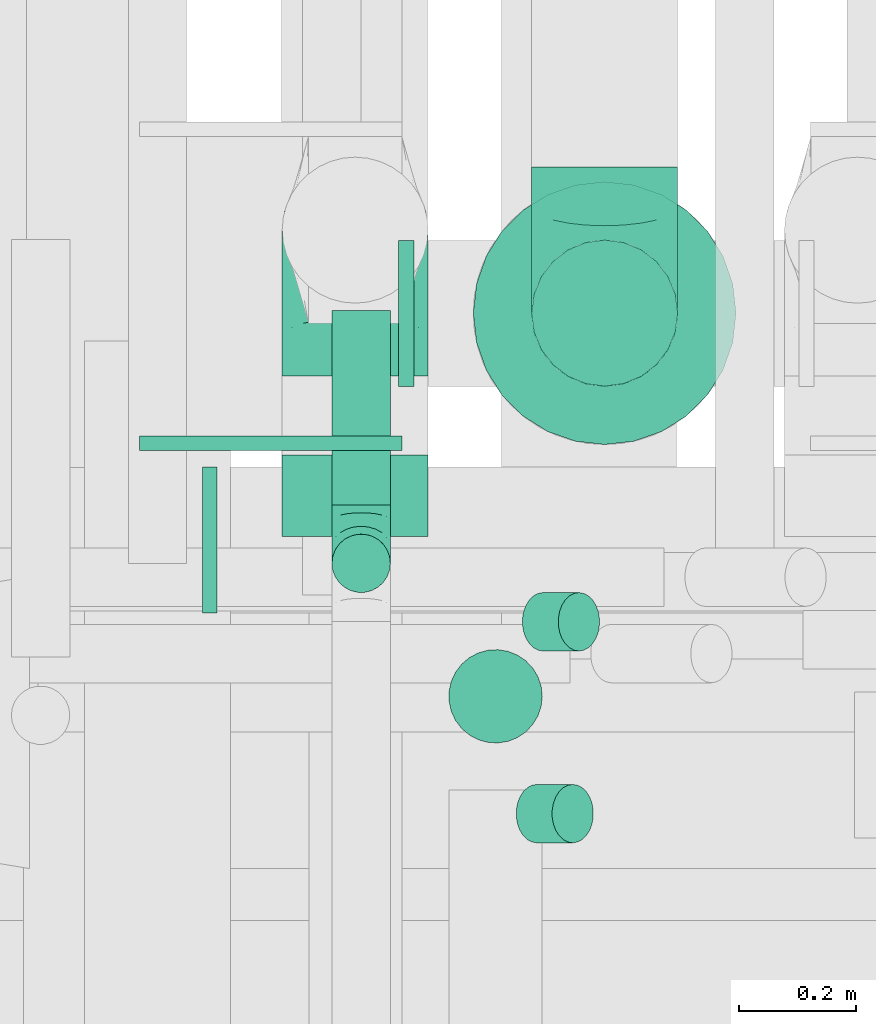
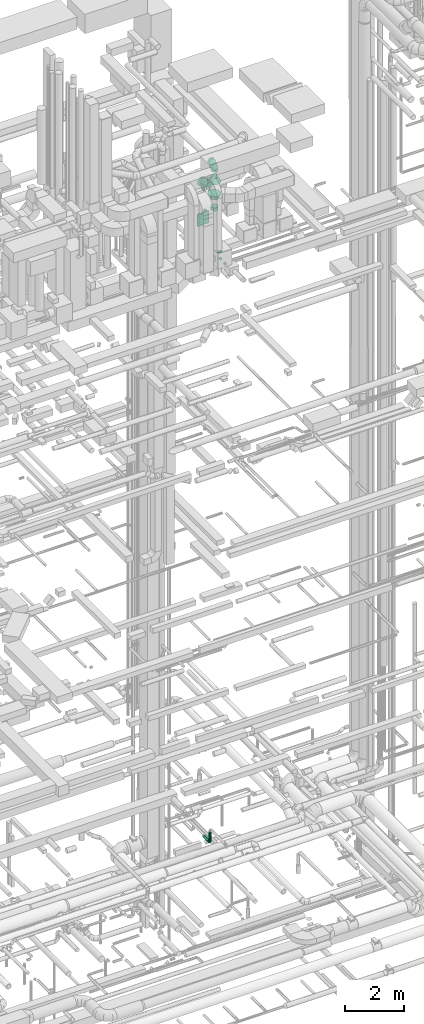
# One storey, part 240 of 337: 10 flow fittings, 5 flow segments.
"""IFC2X3 building model written with IfcOpenShell, lengths in millimetres."""

from ifc_helpers import new_model, entity, si_unit, converted_unit, derived_unit, direction, frame, origin, origin_2d_with_axis, place, context, subcontext, project, spatial, rectangle, circle, extrude, faceted_brep, source, transform, mapped, material, type_object, type_shapes, element, save


model = new_model("IFC2X3")

# Units and contexts
model_context = context("Model", 3, precision=0.01, world=origin(), true_north=direction((6.12303176911189e-17, 1.0)))
body_context = subcontext(model_context, "Body", "Model", "MODEL_VIEW")
ifc_project = project(units=[si_unit("LENGTHUNIT", "METRE", prefix="MILLI"), si_unit("AREAUNIT", "SQUARE_METRE"), si_unit("VOLUMEUNIT", "CUBIC_METRE"), converted_unit("PLANEANGLEUNIT", "DEGREE", entity("IfcRatioMeasure", 0.0174532925199433), si_unit("PLANEANGLEUNIT", "RADIAN"), dimensions=[0, 0, 0, 0, 0, 0, 0]), si_unit("MASSUNIT", "GRAM", prefix="KILO"), derived_unit("MASSDENSITYUNIT", [(si_unit("MASSUNIT", "GRAM", prefix="KILO"), 1), (si_unit("LENGTHUNIT", "METRE"), -3)]), derived_unit("MOMENTOFINERTIAUNIT", [(si_unit("LENGTHUNIT", "METRE"), 4)]), si_unit("TIMEUNIT", "SECOND"), si_unit("FREQUENCYUNIT", "HERTZ"), si_unit("THERMODYNAMICTEMPERATUREUNIT", "DEGREE_CELSIUS"), derived_unit("THERMALTRANSMITTANCEUNIT", [(si_unit("MASSUNIT", "GRAM", prefix="KILO"), 1), (si_unit("THERMODYNAMICTEMPERATUREUNIT", "KELVIN"), -1), (si_unit("TIMEUNIT", "SECOND"), -3)]), derived_unit("VOLUMETRICFLOWRATEUNIT", [(si_unit("LENGTHUNIT", "METRE"), 3), (si_unit("TIMEUNIT", "SECOND"), -1)]), derived_unit("MASSFLOWRATEUNIT", [(si_unit("MASSUNIT", "GRAM", prefix="KILO"), 1), (si_unit("TIMEUNIT", "SECOND"), -1)]), derived_unit("ROTATIONALFREQUENCYUNIT", [(si_unit("TIMEUNIT", "SECOND"), -1)]), si_unit("ELECTRICCURRENTUNIT", "AMPERE"), si_unit("ELECTRICVOLTAGEUNIT", "VOLT"), si_unit("POWERUNIT", "WATT"), si_unit("FORCEUNIT", "NEWTON", prefix="KILO"), si_unit("ILLUMINANCEUNIT", "LUX"), si_unit("LUMINOUSFLUXUNIT", "LUMEN"), si_unit("LUMINOUSINTENSITYUNIT", "CANDELA"), derived_unit("USERDEFINED", [(si_unit("MASSUNIT", "GRAM", prefix="KILO"), -1), (si_unit("LENGTHUNIT", "METRE"), -2), (si_unit("TIMEUNIT", "SECOND"), 3), (si_unit("LUMINOUSFLUXUNIT", "LUMEN"), 1)]), derived_unit("LINEARVELOCITYUNIT", [(si_unit("LENGTHUNIT", "METRE"), 1), (si_unit("TIMEUNIT", "SECOND"), -1)]), si_unit("PRESSUREUNIT", "PASCAL"), derived_unit("USERDEFINED", [(si_unit("LENGTHUNIT", "METRE"), -2), (si_unit("MASSUNIT", "GRAM", prefix="KILO"), 1), (si_unit("TIMEUNIT", "SECOND"), -2)]), derived_unit("LINEARFORCEUNIT", [(si_unit("MASSUNIT", "GRAM", prefix="KILO"), 1), (si_unit("LENGTHUNIT", "METRE"), 1), (si_unit("TIMEUNIT", "SECOND"), -2), (si_unit("LENGTHUNIT", "METRE"), -1)]), derived_unit("PLANARFORCEUNIT", [(si_unit("MASSUNIT", "GRAM", prefix="KILO"), 1), (si_unit("LENGTHUNIT", "METRE"), 1), (si_unit("TIMEUNIT", "SECOND"), -2), (si_unit("LENGTHUNIT", "METRE"), -2)])], contexts=[model_context])

# Site, building, storey
site_placement = place(None, origin())
site = spatial("IfcSite", under=ifc_project, at=site_placement, CompositionType="ELEMENT")
building_placement = place(site_placement, origin())
building = spatial("IfcBuilding", under=site, at=building_placement, CompositionType="ELEMENT")
storey_placement = place(building_placement, origin())
storey = spatial("IfcBuildingStorey", under=building, at=storey_placement, CompositionType="ELEMENT", Elevation=0.0)

# Flow segments
duct_segment_type = type_object("IfcDuctSegmentType", PredefinedType="NOTDEFINED")
flow_segment_1_placement = place(storey_placement, frame((60646.81, 10410.09, 3098.4)))
element("IfcFlowSegment", 1, at=flow_segment_1_placement, inside=storey, type_object=duct_segment_type, context=body_context, shape_type="SweptSolid", body=[
    extrude(circle(Radius=50.0, at=origin_2d_with_axis()), frame((51.6, 0.0, 51.6), z_axis=(0.0, 1.0, 0.0), x_axis=(1.0, 0.0, 0.0)), (0.0, 0.0, 1.0), 332.897563299893),
])
flow_segment_2_placement = place(storey_placement, frame((60846.85, 10000.81, 27460.0)))
element("IfcFlowSegment", 2, at=flow_segment_2_placement, inside=storey, type_object=duct_segment_type, context=body_context, shape_type="SweptSolid", body=[
    extrude(circle(Radius=80.0, at=origin_2d_with_axis()), frame((81.6, 81.6, 0.0)), (0.0, 0.0, 1.0), 19.9999999999608),
])
flow_segment_3_placement = place(storey_placement, frame((60962.21, 9829.93, 26992.34)))
element("IfcFlowSegment", 3, at=flow_segment_3_placement, inside=storey, type_object=duct_segment_type, context=body_context, shape_type="SweptSolid", body=[
    extrude(circle(Radius=50.0, at=origin_2d_with_axis()), frame((36.95, 51.6, 36.95), z_axis=(0.707106781186468, 0.0, 0.707106781186627), x_axis=(0.0, 1.0, 0.0)), (0.0, 0.0, 1.0), 86.8629150101547),
])
flow_segment_4_placement = place(storey_placement, frame((60972.83, 10158.38, 26992.34)))
element("IfcFlowSegment", 4, at=flow_segment_4_placement, inside=storey, type_object=duct_segment_type, context=body_context, shape_type="SweptSolid", body=[
    extrude(circle(Radius=50.0, at=origin_2d_with_axis()), frame((36.95, 51.6, 36.95), z_axis=(0.707106781186555, 0.0, 0.70710678118654), x_axis=(0.0, -1.0, 0.0)), (0.0, 0.0, 1.0), 86.8629150101424),
])
flow_segment_5_placement = place(storey_placement, frame((60646.81, 10258.49, 3250.0)))
element("IfcFlowSegment", 5, at=flow_segment_5_placement, inside=storey, type_object=duct_segment_type, context=body_context, shape_type="SweptSolid", body=[
    extrude(circle(Radius=50.0, at=origin_2d_with_axis()), frame((51.6, 51.6, 0.0), z_axis=(0.0, 0.0, 1.0), x_axis=(-1.0, 0.0, 0.0)), (0.0, 0.0, 1.0), 350.000000000019),
])

# Flow fittings
ifc_material = material()
duct_fitting_type_1 = type_object("IfcDuctFittingType", PredefinedType="NOTDEFINED", material=ifc_material)
shared_shape_1 = source(origin(), body_context, "Body", "SweptSolid", [
    extrude(circle(Radius=124.999999999999, at=origin_2d_with_axis()), frame((0.0, 0.0, 0.0), z_axis=(1.0, 0.0, 0.0), x_axis=(0.0, 1.0, 0.0)), (0.0, 0.0, 1.0), 25.0000000000018),
])
type_shapes(duct_fitting_type_1, [shared_shape_1])
flow_fitting_1_placement = place(storey_placement, frame((60451.97, 10350.19, 30100.0), z_axis=(0.0, 0.0, 1.0), x_axis=(-1.0, 0.0, 0.0)))
element("IfcFlowFitting", 6, at=flow_fitting_1_placement, inside=storey, type_object=duct_fitting_type_1, material=ifc_material, context=body_context, shape_type="MappedRepresentation", body=[
    mapped(shared_shape_1, transform((0.0, 0.0, 0.0), scale=1.0)),
])
duct_fitting_type_2 = type_object("IfcDuctFittingType", PredefinedType="NOTDEFINED", material=ifc_material)
shared_shape_2 = source(origin(), body_context, "Body", "SweptSolid", [
    extrude(rectangle(XDim=24.9999999999999, YDim=450.0, at=origin_2d_with_axis()), frame((12.5, 0.0, -250.0)), (0.0, 0.0, 1.0), 500.0),
])
type_shapes(duct_fitting_type_2, [shared_shape_2])
flow_fitting_2_placement = place(storey_placement, frame((60543.66, 10528.49, 28700.0), z_axis=(0.0, 0.0, 1.0), x_axis=(0.0, -1.0, 0.0)))
element("IfcFlowFitting", 7, at=flow_fitting_2_placement, inside=storey, type_object=duct_fitting_type_2, material=ifc_material, context=body_context, shape_type="MappedRepresentation", body=[
    mapped(shared_shape_2, transform((0.0, 0.0, 0.0), scale=1.0)),
])
duct_fitting_type_3 = type_object("IfcDuctFittingType", PredefinedType="NOTDEFINED", material=ifc_material)
shared_shape_3 = source(origin(), body_context, "Body", "Brep", [
    faceted_brep([(-100.0, 0.0, -50.0), (-100.0, -12.94, -48.3), (-100.0, -25.0, -43.3), (-100.0, -35.36, -35.36), (-100.0, -43.3, -25.0), (-100.0, -48.3, -12.94), (-100.0, -50.0, 0.0), (-100.0, -48.3, 12.94), (-100.0, -43.3, 25.0), (-100.0, -35.36, 35.36), (-100.0, -25.0, 43.3), (-100.0, -12.94, 48.3), (-100.0, 0.0, 50.0), (-100.0, 12.94, 48.3), (-100.0, 25.0, 43.3), (-100.0, 35.36, 35.36), (-100.0, 43.3, 25.0), (-100.0, 48.3, 12.94), (-100.0, 50.0, 0.0), (-100.0, 48.3, -12.94), (-100.0, 43.3, -25.0), (-100.0, 35.36, -35.36), (-100.0, 25.0, -43.3), (-100.0, 12.94, -48.3), (-76.67, 12.94, 48.3), (-79.9, 25.0, 43.3), (-73.21, 0.0, 50.0), (-82.68, 35.36, 35.36), (-86.15, 48.3, 12.94), (-86.6, 50.0, 0.0), (-84.81, 43.3, 25.0), (-84.81, 43.3, -25.0), (-82.68, 35.36, -35.36), (-86.15, 48.3, -12.94), (-76.67, 12.94, -48.3), (-73.21, 0.0, -50.0), (-79.9, 25.0, -43.3), (-69.74, -12.94, -48.3), (-66.51, -25.0, -43.3), (-63.73, -35.36, -35.36), (-61.6, -43.3, -25.0), (-60.26, -48.3, -12.94), (-59.81, -50.0, 0.0), (-60.26, -48.3, 12.94), (-61.6, -43.3, 25.0), (-63.73, -35.36, 35.36), (-66.51, -25.0, 43.3), (-69.74, -12.94, 48.3), (-36.27, 36.27, 48.3), (-45.1, 45.1, 43.3), (-26.79, 26.79, 50.0), (-52.68, 52.68, 35.36), (-58.49, 58.49, 25.0), (-62.15, 62.15, 12.94), (-63.4, 63.4, 0.0), (-62.15, 62.15, -12.94), (-58.49, 58.49, -25.0), (-52.68, 52.68, -35.36), (-36.27, 36.27, -48.3), (-26.79, 26.79, -50.0), (-45.1, 45.1, -43.3), (-17.32, 17.32, -48.3), (-8.49, 8.49, -43.3), (-0.91, 0.91, -35.36), (4.9, -4.9, -25.0), (8.56, -8.56, -12.94), (9.81, -9.81, 0.0), (8.56, -8.56, 12.94), (4.9, -4.9, 25.0), (-0.91, 0.91, 35.36), (-8.49, 8.49, 43.3), (-17.32, 17.32, 48.3), (-12.94, 76.67, 48.3), (-25.0, 79.9, 43.3), (0.0, 73.21, 50.0), (-35.36, 82.68, 35.36), (-43.3, 84.81, 25.0), (-48.3, 86.15, 12.94), (-50.0, 86.6, 0.0), (-48.3, 86.15, -12.94), (-43.3, 84.81, -25.0), (-35.36, 82.68, -35.36), (-12.94, 76.67, -48.3), (0.0, 73.21, -50.0), (-25.0, 79.9, -43.3), (12.94, 69.74, -48.3), (25.0, 66.51, -43.3), (35.36, 63.73, -35.36), (43.3, 61.6, -25.0), (48.3, 60.26, -12.94), (50.0, 59.81, 0.0), (48.3, 60.26, 12.94), (43.3, 61.6, 25.0), (35.36, 63.73, 35.36), (25.0, 66.51, 43.3), (12.94, 69.74, 48.3), (-12.94, 100.0, -48.3), (-25.0, 100.0, -43.3), (-35.36, 100.0, -35.36), (-43.3, 100.0, -25.0), (-48.3, 100.0, -12.94), (-50.0, 100.0, 0.0), (-48.3, 100.0, 12.94), (-43.3, 100.0, 25.0), (-35.36, 100.0, 35.36), (-25.0, 100.0, 43.3), (-12.94, 100.0, 48.3), (0.0, 100.0, 50.0), (12.94, 100.0, 48.3), (25.0, 100.0, 43.3), (35.36, 100.0, 35.36), (43.3, 100.0, 25.0), (48.3, 100.0, 12.94), (50.0, 100.0, 0.0), (48.3, 100.0, -12.94), (43.3, 100.0, -25.0), (35.36, 100.0, -35.36), (25.0, 100.0, -43.3), (12.94, 100.0, -48.3), (0.0, 100.0, -50.0)], [[[0, 1, 2, 3, 4, 5, 6, 7, 8, 9, 10, 11, 12, 13, 14, 15, 16, 17, 18, 19, 20, 21, 22, 23]], [[24, 25, 14, 13]], [[26, 24, 13, 12]], [[14, 25, 27, 15]], [[28, 29, 18, 17]], [[30, 28, 17, 16]], [[15, 27, 30, 16]], [[20, 31, 32, 21]], [[33, 31, 20, 19]], [[18, 29, 33, 19]], [[34, 35, 0, 23]], [[36, 34, 23, 22]], [[32, 36, 22, 21]], [[2, 1, 37, 38]], [[3, 2, 38, 39]], [[0, 35, 37, 1]], [[5, 4, 40, 41]], [[6, 5, 41, 42]], [[3, 39, 40, 4]], [[6, 42, 43, 7]], [[7, 43, 44, 8]], [[8, 44, 45, 9]], [[10, 46, 47, 11]], [[11, 47, 26, 12]], [[10, 9, 45, 46]], [[48, 49, 25, 24]], [[50, 48, 24, 26]], [[27, 25, 49, 51]], [[52, 53, 28, 30]], [[51, 52, 30, 27]], [[29, 28, 53, 54]], [[55, 56, 31, 33]], [[54, 55, 33, 29]], [[57, 32, 31, 56]], [[58, 59, 35, 34]], [[60, 58, 34, 36]], [[57, 60, 36, 32]], [[37, 35, 59, 61]], [[38, 37, 61, 62]], [[39, 38, 62, 63]], [[41, 40, 64, 65]], [[42, 41, 65, 66]], [[63, 64, 40, 39]], [[43, 42, 66, 67]], [[44, 43, 67, 68]], [[68, 69, 45, 44]], [[46, 45, 69, 70]], [[47, 46, 70, 71]], [[26, 47, 71, 50]], [[72, 73, 49, 48]], [[74, 72, 48, 50]], [[51, 49, 73, 75]], [[76, 77, 53, 52]], [[75, 76, 52, 51]], [[54, 53, 77, 78]], [[79, 80, 56, 55]], [[78, 79, 55, 54]], [[81, 57, 56, 80]], [[82, 83, 59, 58]], [[84, 82, 58, 60]], [[81, 84, 60, 57]], [[61, 59, 83, 85]], [[62, 61, 85, 86]], [[63, 62, 86, 87]], [[65, 64, 88, 89]], [[66, 65, 89, 90]], [[87, 88, 64, 63]], [[67, 66, 90, 91]], [[68, 67, 91, 92]], [[92, 93, 69, 68]], [[70, 69, 93, 94]], [[71, 70, 94, 95]], [[50, 71, 95, 74]], [[96, 97, 98, 99, 100, 101, 102, 103, 104, 105, 106, 107, 108, 109, 110, 111, 112, 113, 114, 115, 116, 117, 118, 119]], [[72, 74, 107, 106]], [[73, 72, 106, 105]], [[75, 73, 105, 104]], [[77, 76, 103, 102]], [[78, 77, 102, 101]], [[75, 104, 103, 76]], [[78, 101, 100, 79]], [[79, 100, 99, 80]], [[80, 99, 98, 81]], [[96, 119, 83, 82]], [[97, 96, 82, 84]], [[84, 81, 98, 97]], [[83, 119, 118, 85]], [[85, 118, 117, 86]], [[86, 117, 116, 87]], [[88, 115, 114, 89]], [[89, 114, 113, 90]], [[87, 116, 115, 88]], [[91, 90, 113, 112]], [[92, 91, 112, 111]], [[93, 92, 111, 110]], [[95, 94, 109, 108]], [[74, 95, 108, 107]], [[110, 109, 94, 93]]]),
])
type_shapes(duct_fitting_type_3, [shared_shape_3])
flow_fitting_3_placement = place(storey_placement, frame((60698.4, 10310.09, 3150.0), z_axis=(-1.0, 0.0, 0.0), x_axis=(0.0, -1.0, 0.0)))
element("IfcFlowFitting", 8, at=flow_fitting_3_placement, inside=storey, type_object=duct_fitting_type_3, material=ifc_material, context=body_context, shape_type="MappedRepresentation", body=[
    mapped(shared_shape_3, transform((0.0, 0.0, 0.0), scale=1.0)),
])
duct_fitting_type_4 = type_object("IfcDuctFittingType", PredefinedType="NOTDEFINED", material=ifc_material)
shared_shape_4 = source(origin(), body_context, "Body", "Brep", [
    faceted_brep([(-250.0, 0.0, -125.0), (-250.0, -32.35, -120.74), (-250.0, -62.5, -108.25), (-250.0, -88.39, -88.39), (-250.0, -108.25, -62.5), (-250.0, -120.74, -32.35), (-250.0, -125.0, 0.0), (-250.0, -120.74, 32.35), (-250.0, -108.25, 62.5), (-250.0, -88.39, 88.39), (-250.0, -62.5, 108.25), (-250.0, -32.35, 120.74), (-250.0, 0.0, 125.0), (-250.0, 32.35, 120.74), (-250.0, 62.5, 108.25), (-250.0, 88.39, 88.39), (-250.0, 108.25, 62.5), (-250.0, 120.74, 32.35), (-250.0, 125.0, 0.0), (-250.0, 120.74, -32.35), (-250.0, 108.25, -62.5), (-250.0, 88.39, -88.39), (-250.0, 62.5, -108.25), (-250.0, 32.35, -120.74), (-191.68, 32.35, 120.74), (-199.76, 62.5, 108.25), (-183.01, 0.0, 125.0), (-206.7, 88.39, 88.39), (-215.37, 120.74, 32.35), (-216.51, 125.0, 0.0), (-212.02, 108.25, 62.5), (-212.02, 108.25, -62.5), (-206.7, 88.39, -88.39), (-215.37, 120.74, -32.35), (-191.68, 32.35, -120.74), (-183.01, 0.0, -125.0), (-199.76, 62.5, -108.25), (-174.34, -32.35, -120.74), (-166.27, -62.5, -108.25), (-159.33, -88.39, -88.39), (-154.01, -108.25, -62.5), (-150.66, -120.74, -32.35), (-149.52, -125.0, 0.0), (-150.66, -120.74, 32.35), (-154.01, -108.25, 62.5), (-159.33, -88.39, 88.39), (-166.27, -62.5, 108.25), (-174.34, -32.35, 120.74), (-90.67, 90.67, 120.74), (-112.74, 112.74, 108.25), (-66.99, 66.99, 125.0), (-131.69, 131.69, 88.39), (-146.23, 146.23, 62.5), (-155.38, 155.38, 32.35), (-158.49, 158.49, 0.0), (-155.38, 155.38, -32.35), (-146.23, 146.23, -62.5), (-131.69, 131.69, -88.39), (-90.67, 90.67, -120.74), (-66.99, 66.99, -125.0), (-112.74, 112.74, -108.25), (-43.3, 43.3, -120.74), (-21.23, 21.23, -108.25), (-2.28, 2.28, -88.39), (12.26, -12.26, -62.5), (21.4, -21.4, -32.35), (24.52, -24.52, 0.0), (21.4, -21.4, 32.35), (12.26, -12.26, 62.5), (-2.28, 2.28, 88.39), (-21.23, 21.23, 108.25), (-43.3, 43.3, 120.74), (-32.35, 191.68, 120.74), (-62.5, 199.76, 108.25), (0.0, 183.01, 125.0), (-88.39, 206.7, 88.39), (-108.25, 212.02, 62.5), (-120.74, 215.37, 32.35), (-125.0, 216.51, 0.0), (-120.74, 215.37, -32.35), (-108.25, 212.02, -62.5), (-88.39, 206.7, -88.39), (-32.35, 191.68, -120.74), (0.0, 183.01, -125.0), (-62.5, 199.76, -108.25), (32.35, 174.34, -120.74), (62.5, 166.27, -108.25), (88.39, 159.33, -88.39), (108.25, 154.01, -62.5), (120.74, 150.66, -32.35), (125.0, 149.52, 0.0), (120.74, 150.66, 32.35), (108.25, 154.01, 62.5), (88.39, 159.33, 88.39), (62.5, 166.27, 108.25), (32.35, 174.34, 120.74), (-32.35, 250.0, -120.74), (-62.5, 250.0, -108.25), (-88.39, 250.0, -88.39), (-108.25, 250.0, -62.5), (-120.74, 250.0, -32.35), (-125.0, 250.0, 0.0), (-120.74, 250.0, 32.35), (-108.25, 250.0, 62.5), (-88.39, 250.0, 88.39), (-62.5, 250.0, 108.25), (-32.35, 250.0, 120.74), (0.0, 250.0, 125.0), (32.35, 250.0, 120.74), (62.5, 250.0, 108.25), (88.39, 250.0, 88.39), (108.25, 250.0, 62.5), (120.74, 250.0, 32.35), (125.0, 250.0, 0.0), (120.74, 250.0, -32.35), (108.25, 250.0, -62.5), (88.39, 250.0, -88.39), (62.5, 250.0, -108.25), (32.35, 250.0, -120.74), (0.0, 250.0, -125.0)], [[[0, 1, 2, 3, 4, 5, 6, 7, 8, 9, 10, 11, 12, 13, 14, 15, 16, 17, 18, 19, 20, 21, 22, 23]], [[24, 25, 14, 13]], [[26, 24, 13, 12]], [[14, 25, 27, 15]], [[28, 29, 18, 17]], [[30, 28, 17, 16]], [[15, 27, 30, 16]], [[20, 31, 32, 21]], [[33, 31, 20, 19]], [[18, 29, 33, 19]], [[34, 35, 0, 23]], [[36, 34, 23, 22]], [[21, 32, 36, 22]], [[1, 0, 35, 37]], [[2, 1, 37, 38]], [[38, 39, 3, 2]], [[5, 4, 40, 41]], [[6, 5, 41, 42]], [[39, 40, 4, 3]], [[6, 42, 43, 7]], [[7, 43, 44, 8]], [[8, 44, 45, 9]], [[9, 45, 46, 10]], [[10, 46, 47, 11]], [[26, 12, 11, 47]], [[48, 49, 25, 24]], [[50, 48, 24, 26]], [[27, 25, 49, 51]], [[52, 53, 28, 30]], [[51, 52, 30, 27]], [[29, 28, 53, 54]], [[55, 56, 31, 33]], [[54, 55, 33, 29]], [[32, 31, 56, 57]], [[58, 59, 35, 34]], [[60, 58, 34, 36]], [[57, 60, 36, 32]], [[37, 35, 59, 61]], [[38, 37, 61, 62]], [[39, 38, 62, 63]], [[41, 40, 64, 65]], [[42, 41, 65, 66]], [[63, 64, 40, 39]], [[43, 42, 66, 67]], [[44, 43, 67, 68]], [[68, 69, 45, 44]], [[46, 45, 69, 70]], [[47, 46, 70, 71]], [[26, 47, 71, 50]], [[72, 73, 49, 48]], [[74, 72, 48, 50]], [[51, 49, 73, 75]], [[76, 77, 53, 52]], [[75, 76, 52, 51]], [[54, 53, 77, 78]], [[79, 80, 56, 55]], [[78, 79, 55, 54]], [[57, 56, 80, 81]], [[82, 83, 59, 58]], [[84, 82, 58, 60]], [[81, 84, 60, 57]], [[61, 59, 83, 85]], [[62, 61, 85, 86]], [[63, 62, 86, 87]], [[65, 64, 88, 89]], [[66, 65, 89, 90]], [[87, 88, 64, 63]], [[67, 66, 90, 91]], [[68, 67, 91, 92]], [[92, 93, 69, 68]], [[70, 69, 93, 94]], [[71, 70, 94, 95]], [[50, 71, 95, 74]], [[96, 97, 98, 99, 100, 101, 102, 103, 104, 105, 106, 107, 108, 109, 110, 111, 112, 113, 114, 115, 116, 117, 118, 119]], [[72, 74, 107, 106]], [[73, 72, 106, 105]], [[75, 73, 105, 104]], [[77, 76, 103, 102]], [[78, 77, 102, 101]], [[75, 104, 103, 76]], [[78, 101, 100, 79]], [[79, 100, 99, 80]], [[80, 99, 98, 81]], [[84, 97, 96, 82]], [[82, 96, 119, 83]], [[84, 81, 98, 97]], [[83, 119, 118, 85]], [[85, 118, 117, 86]], [[116, 87, 86, 117]], [[88, 115, 114, 89]], [[89, 114, 113, 90]], [[115, 88, 87, 116]], [[91, 90, 113, 112]], [[92, 91, 112, 111]], [[111, 110, 93, 92]], [[95, 94, 109, 108]], [[74, 95, 108, 107]], [[110, 109, 94, 93]]]),
])
type_shapes(duct_fitting_type_4, [shared_shape_4])
for number, where, z_axis, x_axis in (
    (9, (60688.16, 10880.49, 30100.0), (1.0, 0.0, 0.0), (0.0, 0.0, 1.0)),
    (10, (61115.3, 10738.49, 30600.0), (-1.0, 0.0, 0.0), (0.0, 0.0, 1.0)),
):
    element("IfcFlowFitting", number, at=place(storey_placement, frame(where, z_axis=z_axis, x_axis=x_axis)), inside=storey, type_object=duct_fitting_type_4, material=ifc_material, context=body_context, shape_type="MappedRepresentation", body=[
        mapped(shared_shape_4, transform((0.0, 0.0, 0.0), scale=1.0)),
    ])
duct_fitting_type_5 = type_object("IfcDuctFittingType", PredefinedType="NOTDEFINED", material=ifc_material)
shared_shape_5 = source(origin(), body_context, "Body", "Brep", [
    faceted_brep([(20.0, 0.0, -125.0), (20.0, 32.35, -120.74), (20.0, 62.5, -108.25), (20.0, 88.39, -88.39), (20.0, 108.25, -62.5), (20.0, 120.74, -32.35), (20.0, 125.0, 0.0), (20.0, 120.74, 32.35), (20.0, 108.25, 62.5), (20.0, 88.39, 88.39), (20.0, 62.5, 108.25), (20.0, 32.35, 120.74), (20.0, 0.0, 125.0), (20.0, -32.35, 120.74), (20.0, -62.5, 108.25), (20.0, -88.39, 88.39), (20.0, -108.25, 62.5), (20.0, -120.74, 32.35), (20.0, -125.0, 0.0), (20.0, -120.74, -32.35), (20.0, -108.25, -62.5), (20.0, -88.39, -88.39), (20.0, -62.5, -108.25), (20.0, -32.35, -120.74), (0.0, 0.0, 125.0), (-6.1, 0.0, 125.0), (-6.1, -32.35, 120.74), (0.0, -32.35, 120.74), (-6.1, -62.5, 108.25), (0.0, -62.5, 108.25), (0.0, -88.39, 88.39), (-6.1, -88.39, 88.39), (0.0, -108.25, 62.5), (-6.1, -108.25, 62.5), (-6.1, -120.74, 32.35), (0.0, -120.74, 32.35), (-6.1, -125.0, 0.0), (0.0, -125.0, 0.0), (-6.1, -120.74, -32.35), (0.0, -120.74, -32.35), (-6.1, -108.25, -62.5), (0.0, -108.25, -62.5), (0.0, -88.39, -88.39), (-6.1, -88.39, -88.39), (0.0, -62.5, -108.25), (-6.1, -62.5, -108.25), (-6.1, -32.35, -120.74), (0.0, -32.35, -120.74), (-6.1, 0.0, -125.0), (0.0, 0.0, -125.0), (-6.1, 32.35, -120.74), (0.0, 32.35, -120.74), (-6.1, 62.5, -108.25), (0.0, 62.5, -108.25), (0.0, 88.39, -88.39), (-6.1, 88.39, -88.39), (0.0, 108.25, -62.5), (-6.1, 108.25, -62.5), (-6.1, 120.74, -32.35), (0.0, 120.74, -32.35), (-6.1, 125.0, 0.0), (0.0, 125.0, 0.0), (-6.1, 120.74, 32.35), (0.0, 120.74, 32.35), (-6.1, 108.25, 62.5), (0.0, 108.25, 62.5), (0.0, 88.39, 88.39), (-6.1, 88.39, 88.39), (0.0, 62.5, 108.25), (-6.1, 62.5, 108.25), (-6.1, 32.35, 120.74), (0.0, 32.35, 120.74)], [[[0, 1, 2, 3, 4, 5, 6, 7, 8, 9, 10, 11, 12, 13, 14, 15, 16, 17, 18, 19, 20, 21, 22, 23]], [[13, 12, 24, 25, 26, 27]], [[14, 13, 27, 26, 28, 29]], [[30, 15, 14, 29, 28, 31]], [[17, 16, 32, 33, 34, 35]], [[18, 17, 35, 34, 36, 37]], [[32, 16, 15, 30, 31, 33]], [[19, 18, 37, 36, 38, 39]], [[20, 19, 39, 38, 40, 41]], [[42, 21, 20, 41, 40, 43]], [[23, 22, 44, 45, 46, 47]], [[0, 23, 47, 46, 48, 49]], [[44, 22, 21, 42, 43, 45]], [[1, 0, 49, 48, 50, 51]], [[2, 1, 51, 50, 52, 53]], [[54, 3, 2, 53, 52, 55]], [[5, 4, 56, 57, 58, 59]], [[6, 5, 59, 58, 60, 61]], [[56, 4, 3, 54, 55, 57]], [[7, 6, 61, 60, 62, 63]], [[8, 7, 63, 62, 64, 65]], [[66, 9, 8, 65, 64, 67]], [[11, 10, 68, 69, 70, 71]], [[12, 11, 71, 70, 25, 24]], [[68, 10, 9, 66, 67, 69]], [[46, 45, 43, 40, 38, 36, 34, 33, 31, 28, 26, 25, 70, 69, 67, 64, 62, 60, 58, 57, 55, 52, 50, 48]]]),
])
type_shapes(duct_fitting_type_5, [shared_shape_5])
flow_fitting_4_placement = place(storey_placement, frame((60768.66, 10737.49, 28740.0), z_axis=(0.0, 0.0, -1.0), x_axis=(1.0, 0.0, 0.0)))
element("IfcFlowFitting", 11, at=flow_fitting_4_placement, inside=storey, type_object=duct_fitting_type_5, material=ifc_material, context=body_context, shape_type="MappedRepresentation", body=[
    mapped(shared_shape_5, transform((0.0, 0.0, 0.0), scale=1.0)),
])
duct_fitting_type_6 = type_object("IfcDuctFittingType", PredefinedType="NOTDEFINED", material=ifc_material)
shared_shape_6 = source(origin(), body_context, "Body", "Brep", [
    faceted_brep([(20.0, 0.0, -125.0), (20.0, 32.35, -120.74), (20.0, 62.5, -108.25), (20.0, 88.39, -88.39), (20.0, 108.25, -62.5), (20.0, 120.74, -32.35), (20.0, 125.0, 0.0), (20.0, 120.74, 32.35), (20.0, 108.25, 62.5), (20.0, 88.39, 88.39), (20.0, 62.5, 108.25), (20.0, 32.35, 120.74), (20.0, 0.0, 125.0), (20.0, -32.35, 120.74), (20.0, -62.5, 108.25), (20.0, -88.39, 88.39), (20.0, -108.25, 62.5), (20.0, -120.74, 32.35), (20.0, -125.0, 0.0), (20.0, -120.74, -32.35), (20.0, -108.25, -62.5), (20.0, -88.39, -88.39), (20.0, -62.5, -108.25), (20.0, -32.35, -120.74), (0.0, 0.0, 125.0), (-118.9, 0.0, 125.0), (-118.9, -32.35, 120.74), (0.0, -32.35, 120.74), (-118.9, -62.5, 108.25), (0.0, -62.5, 108.25), (0.0, -88.39, 88.39), (-118.9, -88.39, 88.39), (0.0, -108.25, 62.5), (-118.9, -108.25, 62.5), (-118.9, -120.74, 32.35), (0.0, -120.74, 32.35), (-118.9, -125.0, 0.0), (0.0, -125.0, 0.0), (-118.9, -120.74, -32.35), (0.0, -120.74, -32.35), (-118.9, -108.25, -62.5), (0.0, -108.25, -62.5), (0.0, -88.39, -88.39), (-118.9, -88.39, -88.39), (0.0, -62.5, -108.25), (-118.9, -62.5, -108.25), (-118.9, -32.35, -120.74), (0.0, -32.35, -120.74), (-118.9, 0.0, -125.0), (0.0, 0.0, -125.0), (-118.9, 32.35, -120.74), (0.0, 32.35, -120.74), (-118.9, 62.5, -108.25), (0.0, 62.5, -108.25), (0.0, 88.39, -88.39), (-118.9, 88.39, -88.39), (0.0, 108.25, -62.5), (-118.9, 108.25, -62.5), (-118.9, 120.74, -32.35), (0.0, 120.74, -32.35), (-118.9, 125.0, 0.0), (0.0, 125.0, 0.0), (-118.9, 120.74, 32.35), (0.0, 120.74, 32.35), (-118.9, 108.25, 62.5), (0.0, 108.25, 62.5), (0.0, 88.39, 88.39), (-118.9, 88.39, 88.39), (0.0, 62.5, 108.25), (-118.9, 62.5, 108.25), (-118.9, 32.35, 120.74), (0.0, 32.35, 120.74)], [[[0, 1, 2, 3, 4, 5, 6, 7, 8, 9, 10, 11, 12, 13, 14, 15, 16, 17, 18, 19, 20, 21, 22, 23]], [[13, 12, 24, 25, 26, 27]], [[14, 13, 27, 26, 28, 29]], [[30, 15, 14, 29, 28, 31]], [[17, 16, 32, 33, 34, 35]], [[18, 17, 35, 34, 36, 37]], [[32, 16, 15, 30, 31, 33]], [[19, 18, 37, 36, 38, 39]], [[20, 19, 39, 38, 40, 41]], [[42, 21, 20, 41, 40, 43]], [[23, 22, 44, 45, 46, 47]], [[0, 23, 47, 46, 48, 49]], [[44, 22, 21, 42, 43, 45]], [[1, 0, 49, 48, 50, 51]], [[2, 1, 51, 50, 52, 53]], [[54, 3, 2, 53, 52, 55]], [[5, 4, 56, 57, 58, 59]], [[6, 5, 59, 58, 60, 61]], [[56, 4, 3, 54, 55, 57]], [[7, 6, 61, 60, 62, 63]], [[8, 7, 63, 62, 64, 65]], [[66, 9, 8, 65, 64, 67]], [[11, 10, 68, 69, 70, 71]], [[12, 11, 71, 70, 25, 24]], [[68, 10, 9, 66, 67, 69]], [[46, 45, 43, 40, 38, 36, 34, 33, 31, 28, 26, 25, 70, 69, 67, 64, 62, 60, 58, 57, 55, 52, 50, 48]]]),
])
type_shapes(duct_fitting_type_6, [shared_shape_6])
flow_fitting_5_placement = place(storey_placement, frame((61115.3, 10738.47, 28865.0), z_axis=(1.0, 0.0, 0.0), x_axis=(0.0, 0.00206267254414353, 0.999997872688725)))
element("IfcFlowFitting", 12, at=flow_fitting_5_placement, inside=storey, type_object=duct_fitting_type_6, material=ifc_material, context=body_context, shape_type="MappedRepresentation", body=[
    mapped(shared_shape_6, transform((0.0, 0.0, 0.0), scale=1.0)),
])
duct_fitting_type_7 = type_object("IfcDuctFittingType", PredefinedType="NOTDEFINED", material=ifc_material)
shared_shape_7 = source(origin(), body_context, "Body", "Brep", [
    faceted_brep([(20.0, 32.35, -120.74), (20.0, 62.5, -108.25), (20.0, 88.39, -88.39), (20.0, 108.25, -62.5), (20.0, 120.74, -32.35), (20.0, 125.0, 0.0), (20.0, 120.74, 32.35), (20.0, 108.25, 62.5), (20.0, 88.39, 88.39), (20.0, 62.5, 108.25), (20.0, 32.35, 120.74), (20.0, 0.0, 125.0), (20.0, -32.35, 120.74), (20.0, -62.5, 108.25), (20.0, -88.39, 88.39), (20.0, -108.25, 62.5), (20.0, -120.74, 32.35), (20.0, -125.0, 0.0), (20.0, -120.74, -32.35), (20.0, -108.25, -62.5), (20.0, -88.39, -88.39), (20.0, -62.5, -108.25), (20.0, -32.35, -120.74), (20.0, 0.0, -125.0), (0.0, 0.0, 125.0), (0.0, 32.35, 120.74), (-118.9, 32.35, 120.74), (-118.9, 0.0, 125.0), (0.0, 62.5, 108.25), (-118.9, 62.5, 108.25), (0.0, 88.39, 88.39), (-118.9, 88.39, 88.39), (0.0, 108.25, 62.5), (0.0, 120.74, 32.35), (-118.9, 120.74, 32.35), (-118.9, 108.25, 62.5), (0.0, 125.0, 0.0), (-118.9, 125.0, 0.0), (0.0, 120.74, -32.35), (-118.9, 120.74, -32.35), (0.0, 108.25, -62.5), (-118.9, 108.25, -62.5), (0.0, 88.39, -88.39), (-118.9, 88.39, -88.39), (0.0, 62.5, -108.25), (0.0, 32.35, -120.74), (-118.9, 32.35, -120.74), (-118.9, 62.5, -108.25), (0.0, 0.0, -125.0), (-118.9, 0.0, -125.0), (0.0, -32.35, -120.74), (-118.9, -32.35, -120.74), (0.0, -62.5, -108.25), (-118.9, -62.5, -108.25), (0.0, -88.39, -88.39), (-118.9, -88.39, -88.39), (0.0, -108.25, -62.5), (0.0, -120.74, -32.35), (-118.9, -120.74, -32.35), (-118.9, -108.25, -62.5), (0.0, -125.0, 0.0), (-118.9, -125.0, 0.0), (0.0, -120.74, 32.35), (-118.9, -120.74, 32.35), (0.0, -108.25, 62.5), (-118.9, -108.25, 62.5), (0.0, -88.39, 88.39), (-118.9, -88.39, 88.39), (0.0, -62.5, 108.25), (0.0, -32.35, 120.74), (-118.9, -32.35, 120.74), (-118.9, -62.5, 108.25)], [[[0, 1, 2, 3, 4, 5, 6, 7, 8, 9, 10, 11, 12, 13, 14, 15, 16, 17, 18, 19, 20, 21, 22, 23]], [[24, 11, 10, 25, 26, 27]], [[25, 10, 9, 28, 29, 26]], [[28, 9, 8, 30, 31, 29]], [[32, 7, 6, 33, 34, 35]], [[33, 6, 5, 36, 37, 34]], [[30, 8, 7, 32, 35, 31]], [[36, 5, 4, 38, 39, 37]], [[38, 4, 3, 40, 41, 39]], [[40, 3, 2, 42, 43, 41]], [[44, 1, 0, 45, 46, 47]], [[45, 0, 23, 48, 49, 46]], [[42, 2, 1, 44, 47, 43]], [[48, 23, 22, 50, 51, 49]], [[50, 22, 21, 52, 53, 51]], [[52, 21, 20, 54, 55, 53]], [[56, 19, 18, 57, 58, 59]], [[57, 18, 17, 60, 61, 58]], [[54, 20, 19, 56, 59, 55]], [[60, 17, 16, 62, 63, 61]], [[62, 16, 15, 64, 65, 63]], [[64, 15, 14, 66, 67, 65]], [[68, 13, 12, 69, 70, 71]], [[69, 12, 11, 24, 27, 70]], [[66, 14, 13, 68, 71, 67]], [[49, 51, 53, 55, 59, 58, 61, 63, 65, 67, 71, 70, 27, 26, 29, 31, 35, 34, 37, 39, 41, 43, 47, 46]]]),
])
type_shapes(duct_fitting_type_7, [shared_shape_7])
flow_fitting_6_placement = place(storey_placement, frame((60688.16, 10475.19, 30100.0), z_axis=(0.0, 0.0, -1.0), x_axis=(0.0, 1.0, 0.0)))
element("IfcFlowFitting", 13, at=flow_fitting_6_placement, inside=storey, type_object=duct_fitting_type_7, material=ifc_material, context=body_context, shape_type="MappedRepresentation", body=[
    mapped(shared_shape_7, transform((0.0, 0.0, 0.0), scale=1.0)),
])
duct_fitting_type_8 = type_object("IfcDuctFittingType", PredefinedType="NOTDEFINED", material=ifc_material)
shared_shape_8 = source(origin(), body_context, "Body", "Brep", [
    faceted_brep([(200.0, -50.07, -219.36), (200.0, 0.0, -225.0), (200.0, 50.07, -219.36), (200.0, 97.62, -202.72), (200.0, 140.29, -175.91), (200.0, 175.91, -140.29), (200.0, 202.72, -97.62), (200.0, 219.36, -50.07), (200.0, 225.0, 0.0), (200.0, 219.36, 50.07), (200.0, 202.72, 97.62), (200.0, 175.91, 140.29), (200.0, 140.29, 175.91), (200.0, 97.62, 202.72), (200.0, 50.07, 219.36), (200.0, 0.0, 225.0), (200.0, -50.07, 219.36), (200.0, -97.62, 202.72), (200.0, -140.29, 175.91), (200.0, -175.91, 140.29), (200.0, -202.72, 97.62), (200.0, -219.36, 50.07), (200.0, -225.0, 0.0), (200.0, -219.36, -50.07), (200.0, -202.72, -97.62), (200.0, -175.91, -140.29), (200.0, -140.29, -175.91), (200.0, -97.62, -202.72), (0.0, 38.63, -118.88), (0.0, 0.0, -125.0), (0.0, -38.63, -118.88), (0.0, -73.47, -101.13), (0.0, -101.13, -73.47), (0.0, -118.88, -38.63), (0.0, -125.0, 0.0), (0.0, -118.88, 38.63), (0.0, -101.13, 73.47), (0.0, -73.47, 101.13), (0.0, -38.63, 118.88), (0.0, 0.0, 125.0), (0.0, 38.63, 118.88), (0.0, 73.47, 101.13), (0.0, 101.13, 73.47), (0.0, 118.88, 38.63), (0.0, 125.0, 0.0), (0.0, 118.88, -38.63), (0.0, 101.13, -73.47), (0.0, 73.47, -101.13)], [[[0, 1, 2, 3, 4, 5, 6, 7, 8, 9, 10, 11, 12, 13, 14, 15, 16, 17, 18, 19, 20, 21, 22, 23, 24, 25, 26, 27]], [[28, 29, 30, 31, 32, 33, 34, 35, 36, 37, 38, 39, 40, 41, 42, 43, 44, 45, 46, 47]], [[43, 42, 10]], [[44, 43, 9]], [[9, 8, 44]], [[11, 10, 42]], [[9, 43, 10]], [[42, 41, 12, 11]], [[13, 41, 40]], [[14, 40, 39]], [[12, 41, 13]], [[13, 40, 14]], [[39, 15, 14]], [[38, 37, 17]], [[39, 38, 16]], [[16, 15, 39]], [[18, 17, 37]], [[16, 38, 17]], [[37, 36, 19, 18]], [[20, 36, 35]], [[21, 35, 34]], [[19, 36, 20]], [[20, 35, 21]], [[34, 22, 21]], [[33, 32, 24]], [[34, 33, 23]], [[23, 22, 34]], [[25, 24, 32]], [[23, 33, 24]], [[32, 31, 26, 25]], [[27, 31, 30]], [[0, 30, 29]], [[26, 31, 27]], [[27, 30, 0]], [[29, 1, 0]], [[28, 47, 3]], [[29, 28, 2]], [[2, 1, 29]], [[4, 3, 47]], [[2, 28, 3]], [[47, 46, 5, 4]], [[6, 46, 45]], [[7, 45, 44]], [[5, 46, 6]], [[6, 45, 7]], [[44, 8, 7]]]),
])
type_shapes(duct_fitting_type_8, [shared_shape_8])
for number, where, z_axis, x_axis in (
    (14, (61115.3, 10738.47, 29210.0), (-1.0, 0.0, 0.0), (0.0, 0.0, 1.0)),
    (15, (61115.3, 10738.47, 30091.21), (-1.0, 0.0, 0.0), (0.0, 0.0, -1.0)),
):
    element("IfcFlowFitting", number, at=place(storey_placement, frame(where, z_axis=z_axis, x_axis=x_axis)), inside=storey, type_object=duct_fitting_type_8, material=ifc_material, context=body_context, shape_type="MappedRepresentation", body=[
        mapped(shared_shape_8, transform((0.0, 0.0, 0.0), scale=1.0)),
    ])

save(model, "model.ifc")
